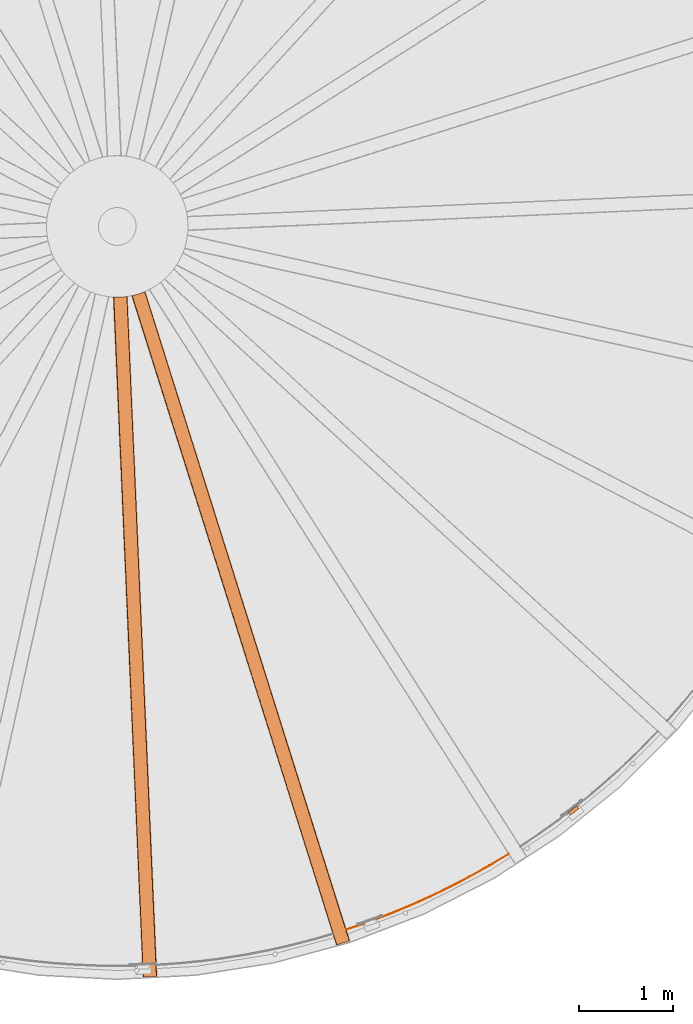
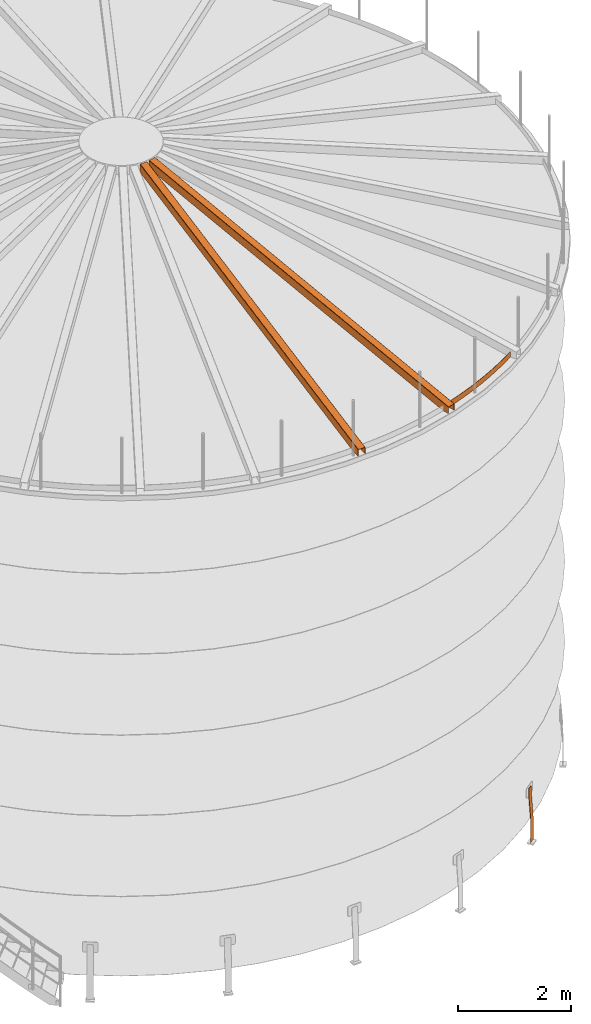
# One storey, part 17 of 126: 4 proxies.
"""IFC2X3 building model written with IfcOpenShell, lengths in millimetres."""

from ifc_helpers import new_model, si_unit, origin, origin_with_axes, place, context, project, spatial, faceted_brep, material, element, save


model = new_model("IFC2X3")

# Units and contexts
context_of_model_1 = context(None, 3, precision=0.1, world=origin())
context_of_model_2 = context(None, 3, precision=0.1, world=origin())
ifc_project = project(units=[si_unit("LENGTHUNIT", "METRE", prefix="MILLI"), si_unit("AREAUNIT", "SQUARE_METRE", prefix="CENTI"), si_unit("VOLUMEUNIT", "CUBIC_METRE", prefix="CENTI"), si_unit("MASSUNIT", "GRAM", prefix="KILO")], contexts=[context_of_model_1, context_of_model_2])

# Site, building, storey
site_placement = place(None, origin_with_axes())
site = spatial("IfcSite", under=ifc_project, at=site_placement, CompositionType="ELEMENT")
building_placement = place(site_placement, origin_with_axes())
building = spatial("IfcBuilding", under=site, at=building_placement, CompositionType="ELEMENT")
storey_placement = place(building_placement, origin_with_axes())
storey = spatial("IfcBuildingStorey", under=building, at=storey_placement, CompositionType="ELEMENT")

# Proxies
ifc_material = material(Name="STAHL")
proxy_1_placement = place(storey_placement, origin_with_axes())
element("IfcBuildingElementProxy", 1, at=proxy_1_placement, inside=storey, material=ifc_material, Name="profile", context=context_of_model_2, shape_type="Brep", body=[
    faceted_brep([(12784.0, 1796.2, 651.1), (12785.9, 1797.8, 654.1), (12781.0, 1804.1, 654.1), (12779.0, 1802.5, 651.1), (12782.5, 1795.1, 647.7), (12777.6, 1801.4, 647.7), (12781.6, 1794.4, 643.9), (12776.7, 1800.7, 643.9), (12804.7, 1764.2, -500.0), (12804.7, 1764.2, 0.0), (12781.3, 1794.2, 540.0), (12781.3, 1794.2, 640.0), (12776.4, 1800.5, 640.0), (12776.4, 1800.5, 540.0), (12799.8, 1770.5, 0.0), (12799.8, 1770.5, -500.0), (12868.3, 1872.3, 651.1), (12866.3, 1870.7, 654.1), (12871.2, 1864.4, 654.1), (12873.2, 1866.0, 651.1), (12874.7, 1867.1, 647.7), (12869.7, 1873.4, 647.7), (12875.6, 1867.8, 643.9), (12870.6, 1874.1, 643.9), (12899.3, 1838.1, 0.0), (12899.3, 1838.1, -500.0), (12894.3, 1844.4, -500.0), (12894.3, 1844.4, 0.0), (12870.9, 1874.3, 540.0), (12870.9, 1874.3, 640.0), (12875.9, 1868.0, 640.0), (12875.9, 1868.0, 540.0), (12794.0, 1804.1, 659.6), (12797.1, 1806.5, 660.0), (12860.1, 1855.7, 660.0), (12863.2, 1858.1, 659.6), (12858.2, 1864.4, 659.6), (12855.2, 1862.0, 660.0), (12792.1, 1812.8, 660.0), (12789.1, 1810.4, 659.6), (12866.1, 1860.4, 658.5), (12861.2, 1866.7, 658.5), (12868.9, 1862.6, 656.6), (12863.9, 1868.9, 656.6), (12786.1, 1808.1, 658.5), (12791.0, 1801.8, 658.5), (12783.4, 1805.9, 656.6), (12788.3, 1799.6, 656.6)], [[[0, 1, 2, 3]], [[4, 0, 3, 5]], [[6, 4, 5, 7]], [[8, 9, 10, 11, 6, 7, 12, 13, 14, 15]], [[16, 17, 18, 19]], [[16, 19, 20, 21]], [[21, 20, 22, 23]], [[24, 25, 26, 27, 28, 29, 23, 22, 30, 31]], [[32, 33, 34, 35, 36, 37, 38, 39]], [[36, 35, 40, 41]], [[41, 40, 42, 43]], [[43, 42, 18, 17]], [[32, 39, 44, 45]], [[45, 44, 46, 47]], [[47, 46, 2, 1]], [[9, 8, 25, 24, 31, 30, 22, 20, 19, 18, 42, 40, 35, 34, 33, 32, 45, 47, 1, 0, 4, 6, 11, 10]], [[14, 13, 12, 7, 5, 3, 2, 46, 44, 39, 38, 37, 36, 41, 43, 17, 16, 21, 23, 29, 28, 27, 26, 15]], [[26, 25, 8, 15]]]),
])
proxy_2_placement = place(storey_placement, origin_with_axes())
element("IfcBuildingElementProxy", 2, at=proxy_2_placement, inside=storey, material=ifc_material, Name="profile", context=context_of_model_2, shape_type="Brep", body=[
    faceted_brep([(8037.7, 7255.7, 12577.1), (7969.6, 7255.8, 12577.9), (7969.2, 7255.9, 12577.9), (7968.8, 7255.9, 12577.8), (7967.9, 7255.9, 12577.6), (7967.2, 7256.0, 12577.1), (7966.6, 7256.0, 12576.5), (7966.1, 7256.0, 12575.8), (7965.8, 7256.0, 12574.9), (7965.6, 7256.0, 12573.9), (7965.6, 7256.0, 12406.2), (7961.6, 7256.3, 12406.3), (7961.6, 7256.3, 12574.0), (7961.7, 7256.2, 12575.4), (7962.1, 7256.2, 12576.8), (7962.8, 7256.2, 12578.2), (7963.7, 7256.1, 12579.5), (7964.8, 7256.1, 12580.5), (7966.1, 7256.0, 12581.3), (7967.8, 7255.9, 12581.9), (7969.6, 7255.8, 12582.1), (8037.7, 7255.7, 12581.2), (8103.5, 7261.5, 12582.0), (8104.4, 7261.6, 12582.0), (8105.3, 7261.7, 12581.8), (8106.9, 7262.0, 12581.3), (8108.4, 7262.2, 12580.4), (8109.6, 7262.3, 12579.2), (8110.5, 7262.5, 12577.8), (8111.2, 7262.6, 12576.0), (8111.5, 7262.6, 12573.9), (8111.5, 7262.6, 12406.2), (8107.5, 7262.0, 12406.1), (8107.5, 7262.0, 12573.8), (8107.4, 7262.0, 12574.5), (8107.3, 7262.0, 12575.2), (8106.9, 7262.0, 12576.0), (8106.5, 7261.9, 12576.6), (8105.9, 7261.8, 12577.1), (8105.3, 7261.7, 12577.5), (8104.5, 7261.6, 12577.8), (8103.5, 7261.5, 12577.9), (8276.3, 49.3, 10641.0), (8276.3, 49.3, 10506.0), (8280.3, 49.4, 10506.0), (8280.3, 49.4, 10641.0), (8280.4, 49.4, 10641.8), (8280.6, 49.4, 10642.6), (8281.0, 49.5, 10643.5), (8281.7, 49.5, 10644.2), (8282.5, 49.5, 10644.7), (8283.3, 49.6, 10645.1), (8284.3, 49.6, 10645.2), (8418.1, 55.5, 10645.2), (8418.9, 55.5, 10645.1), (8419.7, 55.5, 10644.9), (8420.5, 55.6, 10644.4), (8421.2, 55.6, 10643.7), (8421.7, 55.6, 10642.9), (8422.0, 55.6, 10642.0), (8422.1, 55.6, 10641.0), (8422.1, 55.6, 10506.0), (8426.1, 55.8, 10506.0), (8426.1, 55.8, 10641.0), (8426.0, 55.8, 10642.6), (8425.5, 55.8, 10644.2), (8424.6, 55.7, 10645.9), (8423.3, 55.7, 10647.3), (8421.8, 55.6, 10648.4), (8420.0, 55.5, 10649.1), (8418.1, 55.5, 10649.3), (8284.3, 49.6, 10649.3), (8282.7, 49.5, 10649.2), (8281.2, 49.5, 10648.7), (8279.6, 49.4, 10647.7), (8278.2, 49.3, 10646.4), (8277.2, 49.3, 10644.8), (8276.5, 49.3, 10643.0), (8275.0, 171.3, 10506.0), (8271.0, 171.1, 10506.0), (8420.8, 177.7, 10506.0), (8416.8, 177.5, 10506.0)], [[[0, 1, 2, 3, 4, 5, 6, 7, 8, 9, 10, 11, 12, 13, 14, 15, 16, 17, 18, 19, 20, 21, 22, 23, 24, 25, 26, 27, 28, 29, 30, 31, 32, 33, 34, 35, 36, 37, 38, 39, 40, 41]], [[42, 43, 44, 45, 46, 47, 48, 49, 50, 51, 52, 53, 54, 55, 56, 57, 58, 59, 60, 61, 62, 63, 64, 65, 66, 67, 68, 69, 70, 71, 72, 73, 74, 75, 76, 77]], [[10, 78, 79, 11]], [[42, 77, 13, 12, 11, 79, 43]], [[77, 76, 15, 14, 13]], [[15, 76, 75, 16]], [[16, 75, 74, 17]], [[18, 17, 74, 73]], [[19, 18, 73, 72]], [[72, 71, 70, 69, 24, 23, 22, 21, 20, 19]], [[25, 24, 69, 68]], [[26, 25, 68, 67]], [[27, 26, 67, 66]], [[28, 27, 66, 65]], [[29, 28, 65, 64]], [[64, 63, 62, 80, 31, 30, 29]], [[32, 31, 80, 81]], [[61, 81, 80, 62]], [[44, 43, 79, 78]], [[45, 44, 78, 10, 9, 8, 46]], [[8, 7, 47, 46]], [[7, 6, 48, 47]], [[6, 5, 49, 48]], [[5, 4, 50, 49]], [[4, 3, 51, 50]], [[51, 3, 2, 1, 0, 41, 40, 54, 53, 52]], [[40, 39, 55, 54]], [[39, 38, 56, 55]], [[37, 57, 56, 38]], [[36, 58, 57, 37]], [[58, 36, 35, 34, 59]], [[59, 34, 33, 32, 81, 61, 60]]]),
])
proxy_3_placement = place(storey_placement, origin_with_axes())
element("IfcBuildingElementProxy", 3, at=proxy_3_placement, inside=storey, material=ifc_material, Name="profile", context=context_of_model_2, shape_type="Brep", body=[
    faceted_brep([(8156.9, 7270.5, 12406.3), (8156.9, 7270.5, 12574.0), (8157.0, 7270.6, 12575.4), (8157.4, 7270.6, 12576.8), (8158.0, 7270.8, 12578.2), (8158.9, 7271.0, 12579.5), (8160.0, 7271.2, 12580.5), (8161.3, 7271.5, 12581.3), (8162.9, 7271.8, 12581.9), (8164.7, 7272.2, 12582.1), (8230.5, 7289.7, 12581.2), (8292.6, 7312.3, 12582.0), (8293.4, 7312.7, 12582.0), (8294.3, 7313.0, 12581.8), (8295.8, 7313.7, 12581.3), (8297.1, 7314.2, 12580.4), (8298.2, 7314.7, 12579.2), (8299.1, 7315.1, 12577.8), (8299.8, 7315.4, 12576.0), (8300.0, 7315.5, 12573.9), (8300.0, 7315.5, 12406.2), (8296.3, 7313.9, 12406.1), (8296.3, 7313.9, 12573.8), (8296.2, 7313.9, 12574.5), (8296.1, 7313.8, 12575.2), (8295.8, 7313.7, 12576.0), (8295.3, 7313.5, 12576.6), (8294.8, 7313.3, 12577.1), (8294.2, 7313.0, 12577.5), (8293.5, 7312.7, 12577.8), (8292.6, 7312.3, 12577.9), (8230.5, 7289.7, 12577.1), (8164.7, 7272.2, 12577.9), (8164.3, 7272.1, 12577.9), (8163.9, 7272.0, 12577.8), (8163.1, 7271.8, 12577.6), (8162.3, 7271.7, 12577.1), (8161.8, 7271.6, 12576.5), (8161.3, 7271.5, 12575.8), (8160.9, 7271.4, 12574.9), (8160.8, 7271.4, 12573.9), (8160.8, 7271.4, 12406.2), (10326.1, 390.6, 10641.0), (10326.1, 390.6, 10506.0), (10330.0, 391.8, 10506.0), (10330.0, 391.8, 10641.0), (10330.0, 391.8, 10641.8), (10330.2, 391.9, 10642.6), (10330.7, 392.0, 10643.5), (10331.3, 392.2, 10644.2), (10332.0, 392.4, 10644.7), (10332.9, 392.7, 10645.1), (10333.8, 393.0, 10645.2), (10461.6, 433.3, 10645.2), (10462.3, 433.5, 10645.1), (10463.0, 433.7, 10644.9), (10463.8, 434.0, 10644.4), (10464.5, 434.2, 10643.7), (10465.0, 434.3, 10642.9), (10465.3, 434.4, 10642.0), (10465.4, 434.5, 10641.0), (10465.4, 434.5, 10506.0), (10469.2, 435.7, 10506.0), (10469.2, 435.7, 10641.0), (10469.0, 435.6, 10642.6), (10468.6, 435.5, 10644.2), (10467.7, 435.2, 10645.9), (10466.5, 434.8, 10647.3), (10465.0, 434.4, 10648.4), (10463.3, 433.8, 10649.1), (10461.6, 433.3, 10649.3), (10333.8, 393.0, 10649.3), (10332.3, 392.5, 10649.2), (10330.8, 392.0, 10648.7), (10329.3, 391.6, 10647.7), (10328.0, 391.1, 10646.4), (10327.0, 390.8, 10644.8), (10326.3, 390.6, 10643.0), (10293.3, 508.1, 10506.0), (10289.5, 506.9, 10506.0), (10432.5, 552.0, 10506.0), (10428.7, 550.8, 10506.0)], [[[0, 1, 2, 3, 4, 5, 6, 7, 8, 9, 10, 11, 12, 13, 14, 15, 16, 17, 18, 19, 20, 21, 22, 23, 24, 25, 26, 27, 28, 29, 30, 31, 32, 33, 34, 35, 36, 37, 38, 39, 40, 41]], [[42, 43, 44, 45, 46, 47, 48, 49, 50, 51, 52, 53, 54, 55, 56, 57, 58, 59, 60, 61, 62, 63, 64, 65, 66, 67, 68, 69, 70, 71, 72, 73, 74, 75, 76, 77]], [[41, 78, 79, 0]], [[42, 77, 2, 1, 0, 79, 43]], [[77, 76, 4, 3, 2]], [[4, 76, 75, 5]], [[5, 75, 74, 6]], [[7, 6, 74, 73]], [[8, 7, 73, 72]], [[72, 71, 70, 69, 13, 12, 11, 10, 9, 8]], [[14, 13, 69, 68]], [[15, 14, 68, 67]], [[16, 15, 67, 66]], [[17, 16, 66, 65]], [[18, 17, 65, 64]], [[64, 63, 62, 80, 20, 19, 18]], [[21, 20, 80, 81]], [[61, 81, 80, 62]], [[44, 43, 79, 78]], [[45, 44, 78, 41, 40, 39, 46]], [[39, 38, 47, 46]], [[38, 37, 48, 47]], [[37, 36, 49, 48]], [[36, 35, 50, 49]], [[35, 34, 51, 50]], [[51, 34, 33, 32, 31, 30, 29, 54, 53, 52]], [[29, 28, 55, 54]], [[28, 27, 56, 55]], [[26, 57, 56, 27]], [[25, 58, 57, 26]], [[58, 25, 24, 23, 59]], [[59, 23, 22, 21, 81, 61, 60]]]),
])
proxy_4_placement = place(storey_placement, origin_with_axes())
element("IfcBuildingElementProxy", 4, at=proxy_4_placement, inside=storey, material=ifc_material, Name="profile", context=context_of_model_2, shape_type="Brep", body=[
    faceted_brep([(10432.5, 550.4, 10636.0), (10432.5, 550.4, 10516.0), (10657.6, 627.5, 10516.0), (10880.2, 711.4, 10516.0), (11100.2, 802.0, 10516.0), (11317.4, 899.3, 10516.0), (11531.5, 1003.0, 10516.0), (11742.3, 1113.3, 10516.0), (11949.7, 1229.9, 10516.0), (12153.5, 1352.7, 10516.0), (12153.5, 1352.7, 10636.0), (11949.7, 1229.9, 10636.0), (11742.3, 1113.3, 10636.0), (11531.5, 1003.0, 10636.0), (11317.4, 899.3, 10636.0), (11100.2, 802.0, 10636.0), (10880.2, 711.4, 10636.0), (10657.6, 627.5, 10636.0), (12150.8, 1356.9, 10636.0), (11947.2, 1234.2, 10636.0), (11739.9, 1117.7, 10636.0), (11529.2, 1007.5, 10636.0), (11315.3, 903.8, 10636.0), (11098.2, 806.6, 10636.0), (10878.4, 716.1, 10636.0), (10655.9, 632.2, 10636.0), (10431.0, 555.2, 10636.0), (12150.8, 1356.9, 10516.0), (11947.2, 1234.2, 10516.0), (11739.9, 1117.7, 10516.0), (11529.2, 1007.5, 10516.0), (11315.3, 903.8, 10516.0), (11098.2, 806.6, 10516.0), (10878.4, 716.1, 10516.0), (10655.9, 632.2, 10516.0), (10431.0, 555.2, 10516.0)], [[[0, 1, 2, 3, 4, 5, 6, 7, 8, 9, 10, 11, 12, 13, 14, 15, 16, 17]], [[0, 17, 16, 15, 14, 13, 12, 11, 10, 18, 19, 20, 21, 22, 23, 24, 25, 26]], [[26, 25, 24, 23, 22, 21, 20, 19, 18, 27, 28, 29, 30, 31, 32, 33, 34, 35]], [[1, 35, 34, 33, 32, 31, 30, 29, 28, 27, 9, 8, 7, 6, 5, 4, 3, 2]], [[18, 10, 9, 27]], [[26, 35, 1, 0]]]),
])

save(model, "model.ifc")
